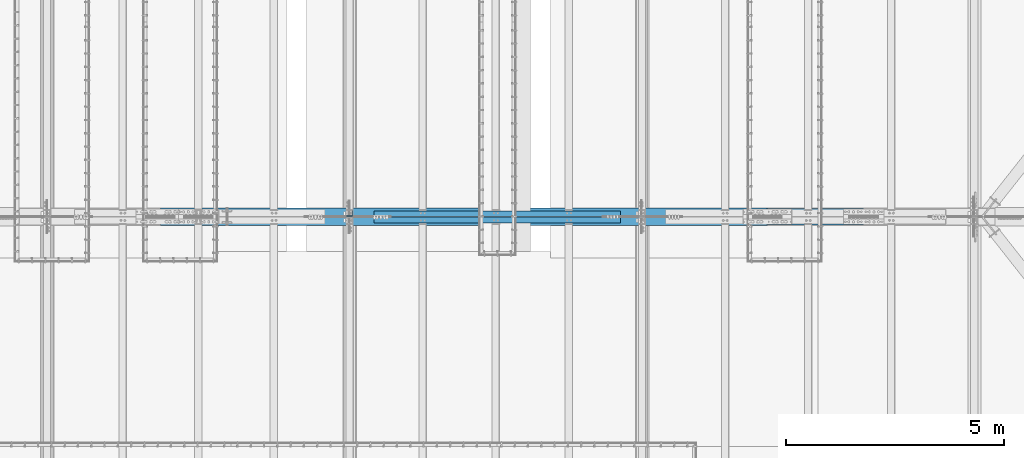
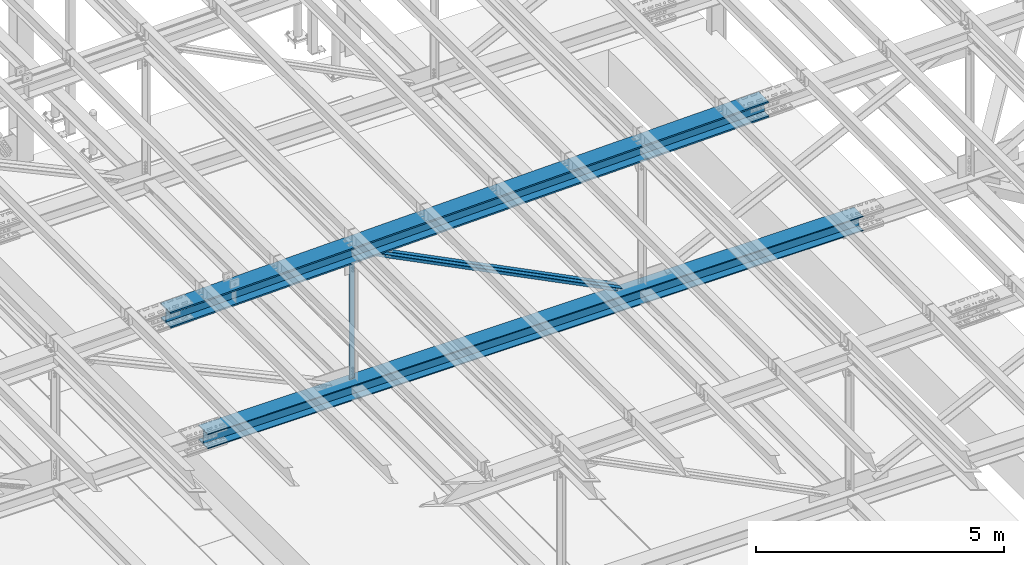
# One storey, part 1892 of 3843: 3 beams, 2 members, 5 elements without a shape of their own.
"""IFC2X3 building model written with IfcOpenShell, lengths in millimetres."""

from ifc_helpers import new_model, si_unit, frame, origin_with_axes, place, context, subcontext, project, spatial, faceted_brep, material, type_object, element, aggregate, save


model = new_model("IFC2X3")

# Units and contexts
model_context = context("Model", 3, precision=1e-05, world=origin_with_axes())
body_context = subcontext(model_context, "Body", "Model", "MODEL_VIEW")
ifc_project = project(units=[si_unit("LENGTHUNIT", "METRE", prefix="MILLI"), si_unit("AREAUNIT", "SQUARE_METRE"), si_unit("VOLUMEUNIT", "CUBIC_METRE"), si_unit("MASSUNIT", "GRAM", prefix="KILO"), si_unit("TIMEUNIT", "SECOND"), si_unit("PLANEANGLEUNIT", "RADIAN"), si_unit("SOLIDANGLEUNIT", "STERADIAN"), si_unit("THERMODYNAMICTEMPERATUREUNIT", "DEGREE_CELSIUS"), si_unit("LUMINOUSINTENSITYUNIT", "LUMEN")], contexts=[model_context])

# Site, building, storey
site_placement = place(None, origin_with_axes())
site = spatial("IfcSite", under=ifc_project, at=site_placement, CompositionType="ELEMENT")
building_placement = place(site_placement, origin_with_axes())
building = spatial("IfcBuilding", under=site, at=building_placement, Name="Undefined", CompositionType="ELEMENT")
storey_placement = place(building_placement, origin_with_axes())
storey = spatial("IfcBuildingStorey", under=building, at=storey_placement, Name="Undefined", CompositionType="ELEMENT", Elevation=0.0)

# Assembly, beam
assembly_1_placement = place(storey_placement, origin_with_axes())
assembly_1 = element("IfcElementAssembly", 1, at=assembly_1_placement, inside=storey, Name="BEAM", AssemblyPlace="NOTDEFINED", PredefinedType="RIGID_FRAME")
ifc_material_1 = material(Name="STEEL/A992")
beam_type_1 = type_object("IfcBeamType", Name="W14X193", PredefinedType="NOTDEFINED")
beam_1_placement = place(assembly_1_placement, frame((51592.2028947097, 67271.9, 45609.415236308), z_axis=(-0.0230720240097944, 0.0, 0.99973380542427), x_axis=(0.99973380542427, 0.0, 0.0230720240097914)))
beam_1 = element("IfcBeam", 2, at=beam_1_placement, type_object=beam_type_1, material=ifc_material_1, Name="BEAM", ObjectType="W14X193", context=body_context, shape_type="Brep", body=[
    faceted_brep([(11138.0356313299, -200.024999999994, 163.291652470798), (11138.0356313299, -11.1125000000029, 163.291652470798), (12530.3163712002, -11.1125000000029, 161.999148991439), (12530.3163712002, -200.024999999994, 161.999148991439), (9745.75459761226, -200.024999999994, 164.214869307005), (9745.75459761226, -11.1125000000029, 164.214869307005), (8353.47336799643, -200.024999999994, 164.768799436744), (8353.47336799643, -11.1125000000029, 164.768799436744), (6961.1920404315, -200.024999999994, 164.953442819955), (6961.1920404315, -11.1125000000029, 164.953442819955), (5568.91071286657, -200.024999999994, 164.768799444537), (5568.91071286657, -11.1125000000029, 164.768799444537), (4176.62948325073, -200.024999999994, 164.214869322583), (4176.62948325073, -11.1125000000029, 164.214869322583), (2784.3484495331, -200.024999999994, 163.291652494168), (2784.3484495331, -11.1125000000029, 163.291652494168), (1392.06770966276, -200.024999999994, 161.999149022595), (1392.06770966276, -11.1125000000029, 161.999149022595), (6.1373568522904, -200.024999999994, 160.344938192073), (6.1373568522904, -11.1125000000029, 160.344938192073), (11138.0356313299, 11.1125000000029, 163.291652470798), (11138.0356313299, 200.024999999994, 163.291652470798), (12530.3163712002, 200.024999999994, 161.999148991439), (12530.3163712002, 11.1125000000029, 161.999148991439), (9745.75459761226, 11.1125000000029, 164.214869307005), (9745.75459761226, 200.024999999994, 164.214869307005), (8353.47336799643, 11.1125000000029, 164.768799436744), (8353.47336799643, 200.024999999994, 164.768799436744), (6961.1920404315, 11.1125000000029, 164.953442819955), (6961.1920404315, 200.024999999994, 164.953442819955), (5568.91071286657, 11.1125000000029, 164.768799444537), (5568.91071286657, 200.024999999994, 164.768799444537), (4176.62948325073, 11.1125000000029, 164.214869322583), (4176.62948325073, 200.024999999994, 164.214869322583), (2784.3484495331, 11.1125000000029, 163.291652494168), (2784.3484495331, 200.024999999994, 163.291652494168), (1392.06770966276, 11.1125000000029, 161.999149022595), (1392.06770966276, 200.024999999994, 161.999149022595), (6.1373568522904, 11.1125000000029, 160.344938192073), (6.1373568522904, 200.024999999994, 160.344938192073), (11137.7804651871, 200.024999999994, -157.383246009093), (11137.7804651871, 11.1125000000029, -157.383246009093), (12529.9761497047, 11.1125000000029, -158.675670528559), (12529.9761497047, 200.024999999994, -158.675670528559), (9745.58448684011, 200.024999999994, -156.460085572813), (9745.58448684011, 11.1125000000029, -156.460085572813), (8353.38831260691, 200.024999999994, -155.906189283029), (8353.38831260691, 11.1125000000029, -155.906189283029), (6961.1920404306, 200.024999999994, -155.721557179815), (6961.1920404306, 11.1125000000029, -155.721557179815), (5568.99576825429, 200.024999999994, -155.906189275243), (5568.99576825429, 11.1125000000029, -155.906189275243), (4176.79959402109, 200.024999999994, -156.460085557235), (4176.79959402109, 11.1125000000029, -156.460085557235), (2784.60361567412, 200.024999999994, -157.383245985737), (2784.60361567412, 11.1125000000029, -157.383245985737), (1392.40793115649, 200.024999999994, -158.675670497403), (1392.40793115649, 11.1125000000029, -158.675670497403), (6.56263357216085, 200.024999999994, -160.329779808199), (6.56263357216085, 11.1125000000029, -160.329779808199), (11137.7514116164, -200.024999999994, -193.89573444987), (11137.7514116164, 200.024999999994, -193.89573444987), (12529.9374116136, 200.024999999994, -195.188149978858), (12529.9374116136, -200.024999999994, -195.188149978858), (9745.56511779179, -200.024999999994, -192.972580435366), (9745.56511779179, 200.024999999994, -192.972580435366), (8353.37862808237, -200.024999999994, -192.418687998652), (8353.37862808237, 200.024999999994, -192.418687998652), (6961.19204043051, -200.024999999994, -192.234057179783), (6961.19204043051, 200.024999999994, -192.234057179783), (5569.00545277863, -200.024999999994, -192.418687990867), (5569.00545277863, 200.024999999994, -192.418687990867), (4176.8189630692, -200.024999999994, -192.972580419788), (4176.8189630692, 200.024999999994, -192.972580419788), (2784.63266924464, -200.024999999994, -193.895734426522), (2784.63266924464, 200.024999999994, -193.895734426522), (1392.44666924737, -200.024999999994, -195.188149947709), (1392.44666924737, 200.024999999994, -195.188149947709), (6.61105616897839, -200.024999999994, -196.842247699315), (6.61105616897839, 200.024999999994, -196.842247699315), (11137.7804651871, -11.1125000000029, -157.383246009093), (11137.7804651871, -200.024999999994, -157.383246009093), (12529.9761497047, -200.024999999994, -158.675670528559), (12529.9761497047, -11.1125000000029, -158.675670528559), (9745.58448684011, -11.1125000000029, -156.460085572813), (9745.58448684011, -200.024999999994, -156.460085572813), (8353.38831260691, -11.1125000000029, -155.906189283029), (8353.38831260691, -200.024999999994, -155.906189283029), (6961.1920404306, -11.1125000000029, -155.721557179815), (6961.1920404306, -200.024999999994, -155.721557179815), (5568.99576825429, -11.1125000000029, -155.906189275243), (5568.99576825429, -200.024999999994, -155.906189275243), (4176.79959402109, -11.1125000000029, -156.460085557235), (4176.79959402109, -200.024999999994, -156.460085557235), (2784.60361567412, -11.1125000000029, -157.383245985737), (2784.60361567412, -200.024999999994, -157.383245985737), (1392.40793115649, -11.1125000000029, -158.675670497403), (1392.40793115649, -200.024999999994, -158.675670497403), (6.56263357216085, -11.1125000000029, -160.329779808199), (6.56263357216085, -200.024999999994, -160.329779808199), (6.08893425547285, -200.024999999994, 196.857406083196), (6.08893425547285, 200.024999999994, 196.857406083196), (1392.02897157188, -200.024999999994, 198.511628472894), (1392.02897157188, 200.024999999994, 198.511628472894), (2784.31939596259, -200.024999999994, 199.804140934939), (2784.31939596259, 200.024999999994, 199.804140934939), (4176.61011420262, -200.024999999994, 200.727364185135), (4176.61011420262, 200.024999999994, 200.727364185135), (5568.90102834222, -200.024999999994, 201.281298160153), (5568.90102834222, 200.024999999994, 201.281298160153), (6961.1920404316, -200.024999999994, 201.465942819923), (6961.1920404316, 200.024999999994, 201.465942819923), (8353.48305252098, -200.024999999994, 201.281298152368), (8353.48305252098, 200.024999999994, 201.281298152368), (9745.77396666058, -200.024999999994, 200.727364169565), (9745.77396666058, 200.024999999994, 200.727364169565), (11138.0646849006, -200.024999999994, 199.804140911576), (11138.0646849006, 200.024999999994, 199.804140911576), (12530.3551092913, -200.024999999994, 198.511628441745), (12530.3551092913, 200.024999999994, 198.511628441745), (13916.2951481047, -200.024999999994, 196.857406042502), (13916.2951481047, 200.024999999994, 196.857406042502), (13916.2467435704, 200.024999999994, 160.344938129827), (13916.2467435704, 11.1125000000029, 160.344938129827), (13915.8216254863, 11.1125000000029, -160.329780059779), (13915.8216254863, 200.024999999994, -160.329780059779), (13915.773220952, 200.024999999994, -196.842247972469), (13915.773220952, -200.024999999994, -196.842247972469), (13915.8216254863, -200.024999999994, -160.329780059779), (13915.8216254863, -11.1125000000029, -160.329780059779), (13916.2467435704, -11.1125000000029, 160.344938129827), (13916.2467435704, -200.024999999994, 160.344938129827)], [[[0, 1, 2, 3]], [[4, 5, 1, 0]], [[6, 7, 5, 4]], [[8, 9, 7, 6]], [[10, 11, 9, 8]], [[12, 13, 11, 10]], [[14, 15, 13, 12]], [[16, 17, 15, 14]], [[17, 16, 18, 19]], [[20, 21, 22, 23]], [[24, 25, 21, 20]], [[26, 27, 25, 24]], [[28, 29, 27, 26]], [[30, 31, 29, 28]], [[32, 33, 31, 30]], [[34, 35, 33, 32]], [[36, 37, 35, 34]], [[37, 36, 38, 39]], [[40, 41, 42, 43]], [[44, 45, 41, 40]], [[46, 47, 45, 44]], [[48, 49, 47, 46]], [[50, 51, 49, 48]], [[52, 53, 51, 50]], [[54, 55, 53, 52]], [[56, 57, 55, 54]], [[57, 56, 58, 59]], [[60, 61, 62, 63]], [[64, 65, 61, 60]], [[66, 67, 65, 64]], [[68, 69, 67, 66]], [[70, 71, 69, 68]], [[72, 73, 71, 70]], [[74, 75, 73, 72]], [[76, 77, 75, 74]], [[77, 76, 78, 79]], [[80, 81, 82, 83]], [[84, 85, 81, 80]], [[86, 87, 85, 84]], [[88, 89, 87, 86]], [[90, 91, 89, 88]], [[92, 93, 91, 90]], [[94, 95, 93, 92]], [[96, 97, 95, 94]], [[97, 96, 98, 99]], [[19, 18, 100, 101, 39, 38, 59, 58, 79, 78, 99, 98]], [[102, 103, 101, 100]], [[103, 102, 104, 105]], [[105, 104, 106, 107]], [[107, 106, 108, 109]], [[109, 108, 110, 111]], [[111, 110, 112, 113]], [[113, 112, 114, 115]], [[115, 114, 116, 117]], [[117, 116, 118, 119]], [[119, 118, 120, 121]], [[22, 21, 25, 27, 29, 31, 33, 35, 37, 39, 101, 103, 105, 107, 109, 111, 113, 115, 117, 119, 121, 122]], [[23, 22, 122, 123]], [[42, 41, 45, 47, 49, 51, 53, 55, 57, 59, 38, 36, 34, 32, 30, 28, 26, 24, 20, 23, 123, 124]], [[43, 42, 124, 125]], [[62, 61, 65, 67, 69, 71, 73, 75, 77, 79, 58, 56, 54, 52, 50, 48, 46, 44, 40, 43, 125, 126]], [[63, 62, 126, 127]], [[82, 81, 85, 87, 89, 91, 93, 95, 97, 99, 78, 76, 74, 72, 70, 68, 66, 64, 60, 63, 127, 128]], [[83, 82, 128, 129]], [[2, 1, 5, 7, 9, 11, 13, 15, 17, 19, 98, 96, 94, 92, 90, 88, 86, 84, 80, 83, 129, 130]], [[3, 2, 130, 131]], [[118, 116, 114, 112, 110, 108, 106, 104, 102, 100, 18, 16, 14, 12, 10, 8, 6, 4, 0, 3, 131, 120]], [[130, 129, 128, 127, 126, 125, 124, 123, 122, 121, 120, 131]]]),
])
aggregate(assembly_1, [beam_1])

assembly_2_placement = place(storey_placement, origin_with_axes())
assembly_2 = element("IfcElementAssembly", 3, at=assembly_2_placement, inside=storey, Name="BEAM", AssemblyPlace="NOTDEFINED", PredefinedType="RIGID_FRAME")
beam_type_2 = type_object("IfcBeamType", Name="W14X120", PredefinedType="NOTDEFINED")
beam_2_placement = place(assembly_2_placement, frame((52463.7000417673, 67271.9, 42319.5670760965), z_axis=(-0.00162875699930737, 0.0, 0.999998673574439), x_axis=(0.999998673574439, 0.0, 0.00162875699930677)))
beam_2 = element("IfcBeam", 4, at=beam_2_placement, type_object=beam_type_2, material=ifc_material_1, Name="BEAM", ObjectType="W14X120", context=body_context, shape_type="Brep", body=[
    faceted_brep([(12202.3170478339, -185.737500000003, 163.884636835646), (12202.3170478339, -7.14375000000291, 163.884636835646), (13727.6354236228, -7.14375000000291, 162.332690249139), (13727.6354236228, -185.737500000003, 162.332690249139), (10676.9982853416, -185.737500000003, 164.99317020653), (10676.9982853416, -7.14375000000291, 164.99317020653), (9151.67926504687, -185.737500000003, 165.658290269588), (9151.67926504687, -7.14375000000291, 165.658290269588), (7626.360115851, -185.737500000003, 165.879996966149), (7626.360115851, -7.14375000000291, 165.879996966149), (6101.04096665512, -185.737500000003, 165.658290279447), (6101.04096665512, -7.14375000000291, 165.658290279447), (4575.72194636041, -185.737500000003, 164.993170226247), (4575.72194636041, -7.14375000000291, 164.993170226247), (3050.40318386804, -185.737500000003, 163.884636865223), (3050.40318386804, -7.14375000000291, 163.884636865223), (1525.08480807913, -185.737500000003, 162.332690288575), (1525.08480807913, -7.14375000000291, 162.332690288575), (6.11694251566951, -185.737500000003, 160.345637435974), (6.11694251566951, -7.14375000000291, 160.345637435974), (12202.3170478339, 7.14375000000291, 163.884636835646), (12202.3170478339, 185.737500000003, 163.884636835646), (13727.6354236228, 185.737500000003, 162.332690249139), (13727.6354236228, 7.14375000000291, 162.332690249139), (10676.9982853416, 7.14375000000291, 164.99317020653), (10676.9982853416, 185.737500000003, 164.99317020653), (9151.67926504687, 7.14375000000291, 165.658290269588), (9151.67926504687, 185.737500000003, 165.658290269588), (7626.360115851, 7.14375000000291, 165.879996966149), (7626.360115851, 185.737500000003, 165.879996966149), (6101.04096665512, 7.14375000000291, 165.658290279447), (6101.04096665512, 185.737500000003, 165.658290279447), (4575.72194636041, 7.14375000000291, 164.993170226247), (4575.72194636041, 185.737500000003, 164.993170226247), (3050.40318386804, 7.14375000000291, 163.884636865223), (3050.40318386804, 185.737500000003, 163.884636865223), (1525.08480807913, 7.14375000000291, 162.332690288575), (1525.08480807913, 185.737500000003, 162.332690288575), (6.11694251566951, 7.14375000000291, 160.345637435974), (6.11694251566951, 185.737500000003, 160.345637435974), (12202.037385243, 185.737500000003, -156.790241215553), (12202.037385243, 7.14375000000291, -156.790241215553), (13727.2625402054, 7.14375000000291, -158.342092953826), (13727.2625402054, 185.737500000003, -158.342092953826), (10676.8118436008, 185.737500000003, -155.68177559341), (10676.8118436008, 7.14375000000291, -155.68177559341), (9151.58604417203, 185.737500000003, -155.016696179591), (9151.58604417203, 7.14375000000291, -155.016696179591), (7626.36011584996, 185.737500000003, -154.795003032777), (7626.36011584996, 7.14375000000291, -154.795003032777), (6101.13418752788, 185.737500000003, -155.016696169732), (6101.13418752788, 7.14375000000291, -155.016696169732), (4575.90838809909, 185.737500000003, -155.681775573692), (4575.90838809909, 7.14375000000291, -155.681775573692), (3050.68284645689, 185.737500000003, -156.790241185976), (3050.68284645689, 7.14375000000291, -156.790241185976), (1525.45769149451, 185.737500000003, -158.342092914398), (1525.45769149451, 7.14375000000291, -158.342092914398), (6.58304672223312, 185.737500000003, -160.3290238193), (6.58304672223312, 7.14375000000291, -160.3290238193), (12202.0166182189, -185.737500000003, -180.602732159947), (12202.0166182189, 185.737500000003, -180.602732159947), (13727.2348508427, 185.737500000003, -182.154576855035), (13727.2348508427, -185.737500000003, -182.154576855035), (10676.7979989171, -185.737500000003, -179.494271568648), (10676.7979989171, 185.737500000003, -179.494271568648), (9151.57912182983, -185.737500000003, -178.829195173341), (9151.57912182983, 185.737500000003, -178.829195173341), (7626.36011584988, -185.737500000003, -178.607503032697), (7626.36011584988, 185.737500000003, -178.607503032697), (6101.14110986992, -185.737500000003, -178.829195163482), (6101.14110986992, 185.737500000003, -178.829195163482), (4575.92223278266, -185.737500000003, -179.494271548931), (4575.92223278266, 185.737500000003, -179.494271548931), (3050.70361348081, -185.737500000003, -180.60273213037), (3050.70361348081, 185.737500000003, -180.60273213037), (1525.48538085704, -185.737500000003, -182.154576815607), (1525.48538085704, 185.737500000003, -182.154576815607), (6.61765842074965, -185.737500000003, -184.141498664983), (6.61765842074965, 185.737500000003, -184.141498664983), (12202.037385243, -7.14375000000291, -156.790241215553), (12202.037385243, -185.737500000003, -156.790241215553), (13727.2625402054, -185.737500000003, -158.342092953826), (13727.2625402054, -7.14375000000291, -158.342092953826), (10676.8118436008, -7.14375000000291, -155.68177559341), (10676.8118436008, -185.737500000003, -155.68177559341), (9151.58604417203, -7.14375000000291, -155.016696179591), (9151.58604417203, -185.737500000003, -155.016696179591), (7626.36011584996, -7.14375000000291, -154.795003032777), (7626.36011584996, -185.737500000003, -154.795003032777), (6101.13418752788, -7.14375000000291, -155.016696169732), (6101.13418752788, -185.737500000003, -155.016696169732), (4575.90838809909, -7.14375000000291, -155.681775573692), (4575.90838809909, -185.737500000003, -155.681775573692), (3050.68284645689, -7.14375000000291, -156.790241185976), (3050.68284645689, -185.737500000003, -156.790241185976), (1525.45769149451, -7.14375000000291, -158.342092914398), (1525.45769149451, -185.737500000003, -158.342092914398), (6.58304672223312, -7.14375000000291, -160.3290238193), (6.58304672223312, -185.737500000003, -160.3290238193), (6.08233081716025, -185.737500000003, 184.158112281657), (6.08233081716025, 185.737500000003, 184.158112281657), (1525.0571187166, -185.737500000003, 186.145174189784), (1525.0571187166, 185.737500000003, 186.145174189784), (3050.38241684411, -185.737500000003, 187.697127809617), (3050.38241684411, 185.737500000003, 187.697127809617), (4575.70810167684, -185.737500000003, 188.805666201486), (4575.70810167684, 185.737500000003, 188.805666201486), (6101.03404431308, -185.737500000003, 189.470789273197), (6101.03404431308, 185.737500000003, 189.470789273197), (7626.36011585107, -185.737500000003, 189.692496966061), (7626.36011585107, 185.737500000003, 189.692496966061), (9151.68618738905, -185.737500000003, 189.470789263331), (9151.68618738905, 185.737500000003, 189.470789263331), (10677.0121300253, -185.737500000003, 188.805666181768), (10677.0121300253, 185.737500000003, 188.805666181768), (12202.337814858, -185.737500000003, 187.697127780033), (12202.337814858, 185.737500000003, 187.697127780033), (13727.6631129855, -185.737500000003, 186.145174150355), (13727.6631129855, 185.737500000003, 186.145174150355), (15246.6378586869, -185.737500000003, 184.158112287609), (15246.6378586869, 185.737500000003, 184.158112287609), (15246.6032581907, 185.737500000003, 160.345637427265), (15246.6032581907, 7.14375000000291, 160.345637427265), (15246.137304843, 7.14375000000291, -160.329024025355), (15246.137304843, 185.737500000003, -160.329024025355), (15246.1027043468, 185.737500000003, -184.1414988857), (15246.1027043468, -185.737500000003, -184.1414988857), (15246.137304843, -185.737500000003, -160.329024025355), (15246.137304843, -7.14375000000291, -160.329024025355), (15246.6032581907, -7.14375000000291, 160.345637427265), (15246.6032581907, -185.737500000003, 160.345637427265)], [[[0, 1, 2, 3]], [[4, 5, 1, 0]], [[6, 7, 5, 4]], [[8, 9, 7, 6]], [[10, 11, 9, 8]], [[12, 13, 11, 10]], [[14, 15, 13, 12]], [[16, 17, 15, 14]], [[17, 16, 18, 19]], [[20, 21, 22, 23]], [[24, 25, 21, 20]], [[26, 27, 25, 24]], [[28, 29, 27, 26]], [[30, 31, 29, 28]], [[32, 33, 31, 30]], [[34, 35, 33, 32]], [[36, 37, 35, 34]], [[37, 36, 38, 39]], [[40, 41, 42, 43]], [[44, 45, 41, 40]], [[46, 47, 45, 44]], [[48, 49, 47, 46]], [[50, 51, 49, 48]], [[52, 53, 51, 50]], [[54, 55, 53, 52]], [[56, 57, 55, 54]], [[57, 56, 58, 59]], [[60, 61, 62, 63]], [[64, 65, 61, 60]], [[66, 67, 65, 64]], [[68, 69, 67, 66]], [[70, 71, 69, 68]], [[72, 73, 71, 70]], [[74, 75, 73, 72]], [[76, 77, 75, 74]], [[77, 76, 78, 79]], [[80, 81, 82, 83]], [[84, 85, 81, 80]], [[86, 87, 85, 84]], [[88, 89, 87, 86]], [[90, 91, 89, 88]], [[92, 93, 91, 90]], [[94, 95, 93, 92]], [[96, 97, 95, 94]], [[97, 96, 98, 99]], [[19, 18, 100, 101, 39, 38, 59, 58, 79, 78, 99, 98]], [[102, 103, 101, 100]], [[103, 102, 104, 105]], [[105, 104, 106, 107]], [[107, 106, 108, 109]], [[109, 108, 110, 111]], [[111, 110, 112, 113]], [[113, 112, 114, 115]], [[115, 114, 116, 117]], [[117, 116, 118, 119]], [[119, 118, 120, 121]], [[22, 21, 25, 27, 29, 31, 33, 35, 37, 39, 101, 103, 105, 107, 109, 111, 113, 115, 117, 119, 121, 122]], [[23, 22, 122, 123]], [[42, 41, 45, 47, 49, 51, 53, 55, 57, 59, 38, 36, 34, 32, 30, 28, 26, 24, 20, 23, 123, 124]], [[43, 42, 124, 125]], [[62, 61, 65, 67, 69, 71, 73, 75, 77, 79, 58, 56, 54, 52, 50, 48, 46, 44, 40, 43, 125, 126]], [[63, 62, 126, 127]], [[82, 81, 85, 87, 89, 91, 93, 95, 97, 99, 78, 76, 74, 72, 70, 68, 66, 64, 60, 63, 127, 128]], [[83, 82, 128, 129]], [[2, 1, 5, 7, 9, 11, 13, 15, 17, 19, 98, 96, 94, 92, 90, 88, 86, 84, 80, 83, 129, 130]], [[3, 2, 130, 131]], [[118, 116, 114, 112, 110, 108, 106, 104, 102, 100, 18, 16, 14, 12, 10, 8, 6, 4, 0, 3, 131, 120]], [[130, 129, 128, 127, 126, 125, 124, 123, 122, 121, 120, 131]]]),
])
aggregate(assembly_2, [beam_2])

assembly_3_placement = place(storey_placement, origin_with_axes())
assembly_3 = element("IfcElementAssembly", 5, at=assembly_3_placement, inside=storey, Name="ANGLE", AssemblyPlace="NOTDEFINED", PredefinedType="RIGID_FRAME")
ifc_material_2 = material(Name="STEEL/A572-50")
beam_type_3 = type_object("IfcBeamType", Name="L5X5X3/8", PredefinedType="NOTDEFINED")
beam_3_placement = place(assembly_3_placement, frame((55930.8, 67344.925, 45713.4854497716), z_axis=(-1.0, 0.0, 0.0), x_axis=(0.0, 0.0, -1.0)))
beam_3 = element("IfcBeam", 6, at=beam_3_placement, type_object=beam_type_3, material=ifc_material_2, Name="ANGLE", ObjectType="L5X5X3/8", context=body_context, shape_type="Brep", body=[
    faceted_brep([(223.664743886766, 63.5, -63.5), (223.664743886766, 63.5, 63.5), (3175.90914098168, 63.5, 63.5), (3175.90914098168, 63.5, -63.5), (223.664743886766, 53.9750000000058, 63.5), (3175.90914098168, 53.9750000000058, 63.5), (223.664743886766, 53.9750000000058, -53.9749999999985), (3175.90914098168, 53.9750000000058, -53.9749999999985), (223.664743886766, -63.5, -53.9749999999985), (3175.90914098168, -63.5, -53.9749999999985), (223.664743886766, -63.5, -63.5), (3175.90914098168, -63.5, -63.5)], [[[0, 1, 2, 3]], [[1, 4, 5, 2]], [[4, 6, 7, 5]], [[6, 8, 9, 7]], [[8, 10, 11, 9]], [[10, 0, 3, 11]], [[5, 7, 9, 11, 3, 2]], [[10, 8, 6, 4, 1, 0]]]),
])
aggregate(assembly_3, [beam_3])

# Assembly, member
assembly_4_placement = place(storey_placement, origin_with_axes())
assembly_4 = element("IfcElementAssembly", 7, at=assembly_4_placement, inside=storey, Name="ANGLE", AssemblyPlace="NOTDEFINED", PredefinedType="RIGID_FRAME")
member_type = type_object("IfcMemberType", Name="L5X5X3/8", PredefinedType="NOTDEFINED")
member_1_placement = place(assembly_4_placement, frame((55930.8, 67344.925, 45713.4854497716), z_axis=(-0.449309268899029, 0.0, -0.893376281799232), x_axis=(0.893376281799232, 0.0, -0.449309268899028)))
member_1 = element("IfcMember", 8, at=member_1_placement, type_object=member_type, material=ifc_material_2, Name="ANGLE", ObjectType="L5X5X3/8", context=body_context, shape_type="Brep", body=[
    faceted_brep([(593.709066530242, 63.5, -63.4999999986467), (593.709066530242, 63.5, 63.5000000012951), (6914.68005033123, 63.5, 63.5000000154978), (6914.68005033123, 63.5, -63.499999984444), (593.709066530242, 53.9750000000058, 63.5000000012951), (6914.68005033123, 53.9750000000058, 63.5000000154978), (593.709066530242, 53.9750000000058, -53.9749999986379), (6914.68005033123, 53.9750000000058, -53.9749999844498), (593.709066530242, -63.5, -53.9749999986379), (6914.68005033123, -63.5, -53.9749999844498), (593.709066530242, -63.5, -63.4999999986467), (6914.68005033123, -63.5, -63.499999984444)], [[[0, 1, 2, 3]], [[1, 4, 5, 2]], [[4, 6, 7, 5]], [[6, 8, 9, 7]], [[8, 10, 11, 9]], [[10, 0, 3, 11]], [[5, 7, 9, 11, 3, 2]], [[10, 8, 6, 4, 1, 0]]]),
])
aggregate(assembly_4, [member_1])

assembly_5_placement = place(storey_placement, origin_with_axes())
assembly_5 = element("IfcElementAssembly", 9, at=assembly_5_placement, inside=storey, Name="ANGLE", AssemblyPlace="NOTDEFINED", PredefinedType="RIGID_FRAME")
member_2_placement = place(assembly_5_placement, frame((62636.3999984813, 67198.875, 42341.0115060771), z_axis=(-0.449309268899029, 0.0, -0.893376281799232), x_axis=(-0.893376281799232, 0.0, 0.449309268899028)))
member_2 = element("IfcMember", 10, at=member_2_placement, type_object=member_type, material=ifc_material_2, Name="ANGLE", ObjectType="L5X5X3/8", context=body_context, shape_type="Brep", body=[
    faceted_brep([(591.227745560704, 63.5, -63.5000000012806), (591.227745560704, 63.5, 63.4999999986612), (6912.19872936169, 63.5, 63.4999999844586), (6912.19872936169, 63.5, -63.5000000154832), (591.227745560704, 53.9750000000058, 63.4999999986612), (6912.19872936169, 53.9750000000058, 63.4999999844586), (591.227745560704, 53.9750000000058, -53.9750000012864), (6912.19872936169, 53.9750000000058, -53.9750000154891), (591.227745560704, -63.5, -53.9750000012864), (6912.19872936169, -63.5, -53.9750000154891), (591.227745560704, -63.5, -63.5000000012806), (6912.19872936169, -63.5, -63.5000000154832)], [[[0, 1, 2, 3]], [[1, 4, 5, 2]], [[4, 6, 7, 5]], [[6, 8, 9, 7]], [[8, 10, 11, 9]], [[10, 0, 3, 11]], [[5, 7, 9, 11, 3, 2]], [[10, 8, 6, 4, 1, 0]]]),
])
aggregate(assembly_5, [member_2])

save(model, "model.ifc")
